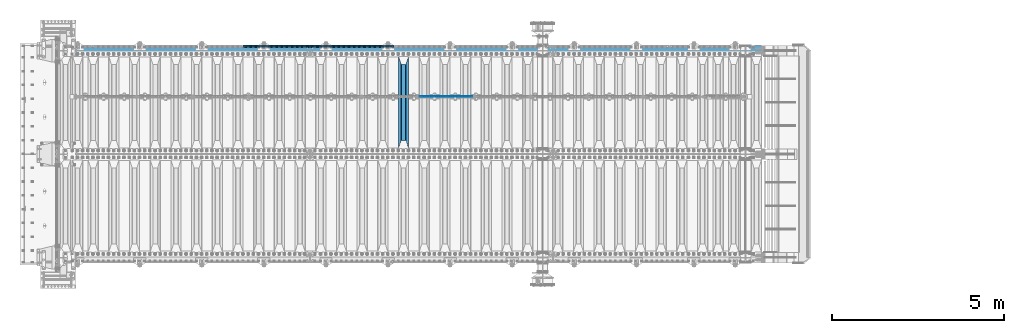
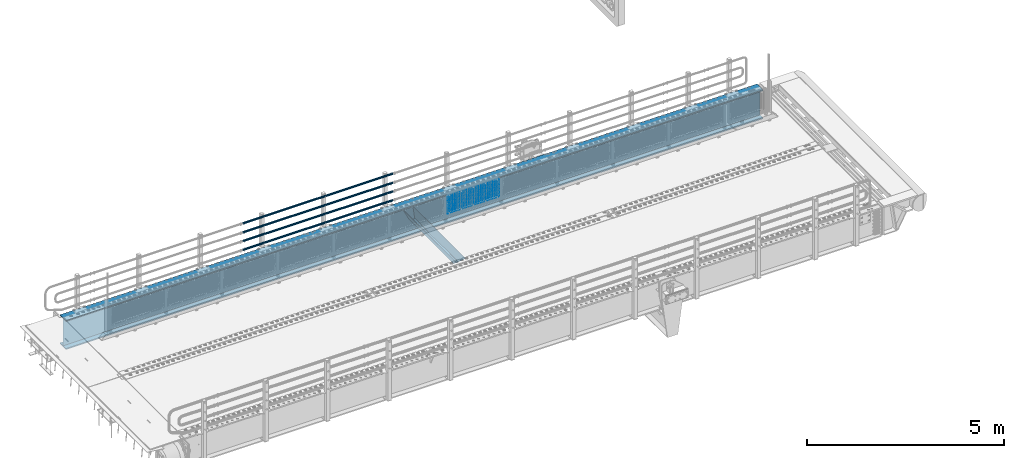
# One storey, part 124 of 242: 23 beams.
"""IFC2X3 building model written with IfcOpenShell, lengths in millimetres."""

import ifcopenshell
import ifcopenshell.guid

model = None  # the IFC model being written
_history = None  # IfcOwnerHistory: only IFC2X3 demands one
_inside = {}  # id of a spatial element -> (the spatial element, [elements in it])
_under = {}  # id of a project, library or spatial element -> (it, [spatial elements below it])
_declared = {}  # id of a project -> (the project, [libraries it declares])
_typed = {}  # id of a type object -> (the type object, [elements of that type])
_made_of = {}  # id of a material, layer set ... -> (it, [elements and type objects made of it])


def new_model(schema):
    """Start an empty IFC model of exactly this schema.

    Asked for "IFC4X3", IfcOpenShell would pick the latest addendum, in which some entities
    have other attributes; the version numbers below select the first issue.
    IFC2X3 requires an IfcOwnerHistory on every rooted entity: one is made here for all.
    """
    global model, _history
    if schema == "IFC4X3":
        model = ifcopenshell.file(schema_version=(4, 3, 0, 0))
    else:
        model = ifcopenshell.file(schema=schema)
    _inside.clear()
    _under.clear()
    _declared.clear()
    _typed.clear()
    _made_of.clear()
    _history = None
    if model.schema == "IFC2X3":
        org = make("IfcOrganization", Name="unknown")
        user = make(
            "IfcPersonAndOrganization",
            ThePerson=make("IfcPerson", FamilyName="unknown"),
            TheOrganization=org,
        )
        app = make(
            "IfcApplication",
            ApplicationDeveloper=org,
            Version="unknown",
            ApplicationFullName="unknown",
            ApplicationIdentifier="unknown",
        )
        _history = make(
            "IfcOwnerHistory",
            OwningUser=user,
            OwningApplication=app,
            ChangeAction="ADDED",
            CreationDate=0,
        )
    return model


def make(cls, **values):
    """One entity of the class cls with the attributes given. An attribute that is None is left unset."""
    return model.create_entity(
        cls, **{name: value for name, value in values.items() if value is not None}
    )


def rooted(cls, **values):
    """An entity with a GlobalId (a new one), such as an element, a storey or a relation."""
    return make(cls, GlobalId=ifcopenshell.guid.new(), OwnerHistory=_history, **values)


def si_unit(unit_type, name, prefix=None):
    """IfcSIUnit, for example si_unit("LENGTHUNIT", "METRE", prefix="MILLI")."""
    return make("IfcSIUnit", UnitType=unit_type, Prefix=prefix, Name=name)


def assignment(units):
    """IfcUnitAssignment: the units of a project."""
    return None if units is None else make("IfcUnitAssignment", Units=units)


def point(xyz):
    """IfcCartesianPoint."""
    return None if xyz is None else make("IfcCartesianPoint", Coordinates=xyz)


def direction(xyz):
    """IfcDirection."""
    return None if xyz is None else make("IfcDirection", DirectionRatios=xyz)


def frame(location, z_axis=None, x_axis=None):
    """IfcAxis2Placement3D, a coordinate frame: its origin and axes. An axis left out is left unset."""
    return make(
        "IfcAxis2Placement3D",
        Location=point(location),
        Axis=direction(z_axis),
        RefDirection=direction(x_axis),
    )


def origin_with_axes():
    """The frame at (0, 0, 0) with the z axis (0, 0, 1) and the x axis (1, 0, 0) written out."""
    return frame((0.0, 0.0, 0.0), z_axis=(0.0, 0.0, 1.0), x_axis=(1.0, 0.0, 0.0))


def place(relative_to, where):
    """IfcLocalPlacement: puts the frame where relative to a parent placement (None: the world)."""
    return make(
        "IfcLocalPlacement", PlacementRelTo=relative_to, RelativePlacement=where
    )


def context(
    kind, dimensions, precision=None, world=None, true_north=None, identifier=None
):
    """IfcGeometricRepresentationContext, for example the 3D "Model" context."""
    return make(
        "IfcGeometricRepresentationContext",
        ContextIdentifier=identifier,
        ContextType=kind,
        CoordinateSpaceDimension=dimensions,
        Precision=precision,
        WorldCoordinateSystem=world,
        TrueNorth=true_north,
    )


def subcontext(parent, identifier, kind, view, scale=None):
    """IfcGeometricRepresentationSubContext, for example "Body" below "Model"."""
    return make(
        "IfcGeometricRepresentationSubContext",
        ContextIdentifier=identifier,
        ContextType=kind,
        ParentContext=parent,
        TargetScale=scale,
        TargetView=view,
    )


def project(units=None, contexts=None):
    """IfcProject with its units and contexts."""
    return rooted(
        "IfcProject",
        Name="project",
        RepresentationContexts=contexts,
        UnitsInContext=assignment(units),
    )


def spatial(cls, under=None, at=None, **own):
    """A site, building, storey or space (cls), placed at a placement, below another one or the project."""
    s = rooted(cls, ObjectPlacement=at, **own)
    if under is not None:
        _under.setdefault(under.id(), (under, []))[1].append(s)
    return s


def faces_of(points, faces, orient=None, outer=None):
    """IfcFace entities. A face is a list of loops; a loop is a list of indices into points, from 0.

    orient and outer hold one flag for each loop. By default every Orientation is true, the
    first loop of a face is its IfcFaceOuterBound and the others are IfcFaceBound.
    """
    made = []
    for i, loops in enumerate(faces):
        bounds = []
        for j, loop in enumerate(loops):
            is_outer = j == 0 if outer is None else outer[i][j]
            bounds.append(
                make(
                    "IfcFaceOuterBound" if is_outer else "IfcFaceBound",
                    Bound=make("IfcPolyLoop", Polygon=[points[k] for k in loop]),
                    Orientation=True if orient is None else orient[i][j],
                )
            )
        made.append(make("IfcFace", Bounds=bounds))
    return made


def faceted_brep(points, faces, orient=None, outer=None, voids=None):
    """IfcFacetedBrep: a solid bounded by flat faces; with voids (closed shells), ...WithVoids."""
    shared = [point(p) for p in points]
    hull = make("IfcClosedShell", CfsFaces=faces_of(shared, faces, orient, outer))
    if voids is None:
        return make("IfcFacetedBrep", Outer=hull)
    return make(
        "IfcFacetedBrepWithVoids",
        Outer=hull,
        Voids=[
            make(cls, CfsFaces=faces_of(shared, fs, o, b)) for cls, fs, o, b in voids
        ],
    )


def shape(context_of_items, identifier, shape_type, items):
    """IfcShapeRepresentation: the items that make up one representation, for example the "Body"."""
    return make(
        "IfcShapeRepresentation",
        ContextOfItems=context_of_items,
        RepresentationIdentifier=identifier,
        RepresentationType=shape_type,
        Items=items,
    )


def material(Name=None, Category=None):
    """IfcMaterial."""
    return make("IfcMaterial", Name=Name, Category=Category)


def made_of(thing, what):
    """Note that an element or type object is made of a material, layer set ...; save() writes the relation."""
    if what is not None:
        _made_of.setdefault(what.id(), (what, []))[1].append(thing)
    return thing


def type_object(cls, material=None, **own):
    """A type object (cls), such as IfcWallType, which elements share."""
    return made_of(rooted(cls, **own), material)


def element(
    cls,
    number,
    at=None,
    inside=None,
    cuts=None,
    type_object=None,
    material=None,
    context=None,
    identifier="Body",
    shape_type=None,
    held_by="IfcProductDefinitionShape",
    body=None,
    shapes=None,
    **own,
):
    """One element of the class cls, such as IfcWall. Its Tag is "e" and its number.

    at: its placement. inside: the storey or other place that contains it. cuts: it is an
    opening in that element (IfcRelVoidsElement). A single representation is given by context,
    identifier, shape_type and body (its items); several are given by shapes. held_by: the class
    of the entity that holds the representations. save() writes the other relations.
    """
    e = rooted(cls, Tag="e%d" % number, ObjectPlacement=at, **own)
    if body is not None:
        shapes = [shape(context, identifier, shape_type, body)]
    if shapes is not None:
        e.Representation = make(held_by, Representations=shapes)
    if inside is not None:
        _inside.setdefault(inside.id(), (inside, []))[1].append(e)
    if cuts is not None:
        rooted(
            "IfcRelVoidsElement", RelatingBuildingElement=cuts, RelatedOpeningElement=e
        )
    if type_object is not None:
        _typed.setdefault(type_object.id(), (type_object, []))[1].append(e)
    return made_of(e, material)


def aggregate(whole, parts):
    """IfcRelAggregates: a whole, such as a stair, and the parts it consists of."""
    return rooted("IfcRelAggregates", RelatingObject=whole, RelatedObjects=parts)


def save(model, path):
    """Write the relations noted so far, then the file.

    IfcRelAggregates (storeys below a building ...), IfcRelContainedInSpatialStructure (elements
    in a storey), IfcRelDefinesByType, IfcRelAssociatesMaterial and IfcRelDeclares: one each for
    every whole, place, type object, material and project.
    """
    for whole, parts in _under.values():
        aggregate(whole, parts)
    for where, things in _inside.values():
        rooted(
            "IfcRelContainedInSpatialStructure",
            RelatedElements=things,
            RelatingStructure=where,
        )
    for kind, things in _typed.values():
        rooted("IfcRelDefinesByType", RelatedObjects=things, RelatingType=kind)
    for what, things in _made_of.values():
        rooted("IfcRelAssociatesMaterial", RelatedObjects=things, RelatingMaterial=what)
    for by, libraries in _declared.values():
        rooted("IfcRelDeclares", RelatingContext=by, RelatedDefinitions=libraries)
    model.write(path)


model = new_model("IFC2X3")

# Units and contexts
model_context = context("Model", 3, precision=1e-05, world=origin_with_axes())
body_context = subcontext(model_context, "Body", "Model", "MODEL_VIEW")
ifc_project = project(units=[si_unit("LENGTHUNIT", "METRE", prefix="MILLI"), si_unit("AREAUNIT", "SQUARE_METRE"), si_unit("VOLUMEUNIT", "CUBIC_METRE"), si_unit("MASSUNIT", "GRAM", prefix="KILO"), si_unit("TIMEUNIT", "SECOND"), si_unit("PLANEANGLEUNIT", "RADIAN"), si_unit("SOLIDANGLEUNIT", "STERADIAN"), si_unit("THERMODYNAMICTEMPERATUREUNIT", "DEGREE_CELSIUS"), si_unit("LUMINOUSINTENSITYUNIT", "LUMEN")], contexts=[model_context])

# Site, building, storey
site_placement = place(None, origin_with_axes())
site = spatial("IfcSite", under=ifc_project, at=site_placement, CompositionType="ELEMENT")
building_placement = place(site_placement, origin_with_axes())
building = spatial("IfcBuilding", under=site, at=building_placement, Name="Standard", CompositionType="ELEMENT")
storey_placement = place(building_placement, origin_with_axes())
storey = spatial("IfcBuildingStorey", under=building, at=storey_placement, Name="Undefined", CompositionType="ELEMENT", Elevation=0.0)

# Beams
ifc_material_1 = material(Name="Misc_Undefined")
beam_type_1 = type_object("IfcBeamType", Name="D3", PredefinedType="NOTDEFINED")
for number, where, z_axis, x_axis in (
    (1, (-31976.0, -19329.5, 851.596999999999), (0.0, 0.0, 1.0), (1.0, 0.0, 0.0)),
    (2, (-31976.0, -19329.5, 669.452), (0.0, 0.0, 1.0), (1.0, 0.0, 0.0)),
    (3, (-31976.0, -19329.5, 523.736), (0.0, 0.0, 1.0), (1.0, 0.0, 0.0)),
    (4, (-31976.0, -19329.5, 487.307), (0.0, 0.0, 1.0), (1.0, 0.0, 0.0)),
    (5, (-31976.0, -19329.5, 705.881), (0.0, 0.0, 1.0), (1.0, 0.0, 0.0)),
    (6, (-31976.0, -19329.5, 596.594), (0.0, 0.0, 1.0), (1.0, 0.0, 0.0)),
    (7, (-31976.0, -19329.5, 450.878), (0.0, 0.0, 1.0), (1.0, 0.0, 0.0)),
    (8, (-31976.0, -19329.5, 815.167999999999), (0.0, 0.0, 1.0), (1.0, 0.0, 0.0)),
    (9, (-31976.0, -19329.5, 888.025999999999), (0.0, 0.0, 1.0), (1.0, 0.0, 0.0)),
    (10, (-31976.0, -19329.5, 778.738999999999), (0.0, 0.0, 1.0), (1.0, 0.0, 0.0)),
    (11, (-31976.0, -19329.5, 742.309999999999), (0.0, 0.0, 1.0), (1.0, 0.0, 0.0)),
    (12, (-31976.0, -19329.5, 633.023), (0.0, 0.0, 1.0), (1.0, 0.0, 0.0)),
    (13, (-31976.0, -19329.5, 560.165), (0.0, 0.0, 1.0), (1.0, 0.0, 0.0)),
    (14, (-31976.0, -19329.5, 414.449), (0.0, 0.0, 1.0), (1.0, 0.0, 0.0)),
):
    element("IfcBeam", number, at=place(storey_placement, frame(where, z_axis=z_axis, x_axis=x_axis)), inside=storey, type_object=beam_type_1, material=ifc_material_1, ObjectType="D3", context=body_context, shape_type="Brep", body=[
        faceted_brep([(0.0, -1.50000000000364, 0.0), (-3.63797880709171e-12, -0.750000000003638, -1.29903810567669), (1523.0, -0.75, -1.29903810567669), (1523.0, -1.5, 0.0), (0.0, 0.749999999996362, -1.29903810567669), (1523.0, 0.75, -1.29903810567669), (-3.63797880709171e-12, 1.49999999999636, 0.0), (1523.0, 1.5, 0.0), (0.0, 0.749999999996362, 1.29903810567669), (1523.0, 0.75, 1.29903810567669), (-3.63797880709171e-12, -0.750000000003638, 1.29903810567669), (1523.0, -0.75, 1.29903810567669)], [[[0, 1, 2, 3]], [[1, 4, 5, 2]], [[4, 6, 7, 5]], [[6, 8, 9, 7]], [[8, 10, 11, 9]], [[10, 0, 3, 11]], [[5, 7, 9, 11, 3, 2]], [[10, 8, 6, 4, 1, 0]]]),
    ])
beam_1_placement = place(storey_placement, frame((-31951.0, -19329.5, 353.02), z_axis=(0.0, 0.0, 1.0), x_axis=(1.0, 0.0, 0.0)))
element("IfcBeam", 15, at=beam_1_placement, inside=storey, type_object=beam_type_1, material=ifc_material_1, ObjectType="D3", context=body_context, shape_type="Brep", body=[
    faceted_brep([(0.0, -1.50000000000364, 0.0), (-3.63797880709171e-12, -0.750000000003638, -1.29903810567669), (1473.0, -0.75, -1.29903810567669), (1473.0, -1.5, 0.0), (0.0, 0.749999999996362, -1.29903810567669), (1473.0, 0.75, -1.29903810567663), (-3.63797880709171e-12, 1.49999999999636, 0.0), (1473.0, 1.5, 0.0), (0.0, 0.749999999996362, 1.29903810567669), (1473.0, 0.75, 1.29903810567669), (-3.63797880709171e-12, -0.750000000003638, 1.29903810567669), (1473.0, -0.75, 1.29903810567669)], [[[0, 1, 2, 3]], [[1, 4, 5, 2]], [[4, 6, 7, 5]], [[6, 8, 9, 7]], [[8, 10, 11, 9]], [[10, 0, 3, 11]], [[5, 7, 9, 11, 3, 2]], [[10, 8, 6, 4, 1, 0]]]),
])
beam_2_placement = place(storey_placement, frame((-31976.0, -19329.5, 378.02), z_axis=(0.0, 0.0, 1.0), x_axis=(1.0, 0.0, 0.0)))
element("IfcBeam", 16, at=beam_2_placement, inside=storey, type_object=beam_type_1, material=ifc_material_1, ObjectType="D3", context=body_context, shape_type="Brep", body=[
    faceted_brep([(0.0, -1.50000000000364, 0.0), (-3.63797880709171e-12, -0.750000000003638, -1.29903810567669), (1523.0, -0.75, -1.29903810567669), (1523.0, -1.5, 0.0), (0.0, 0.749999999996362, -1.29903810567669), (1523.0, 0.75, -1.29903810567669), (-3.63797880709171e-12, 1.49999999999636, 0.0), (1523.0, 1.5, 0.0), (0.0, 0.749999999996362, 1.29903810567669), (1523.0, 0.75, 1.29903810567669), (-3.63797880709171e-12, -0.750000000003638, 1.29903810567669), (1523.0, -0.75, 1.29903810567669)], [[[0, 1, 2, 3]], [[1, 4, 5, 2]], [[4, 6, 7, 5]], [[6, 8, 9, 7]], [[8, 10, 11, 9]], [[10, 0, 3, 11]], [[5, 7, 9, 11, 3, 2]], [[10, 8, 6, 4, 1, 0]]]),
])
beam_3_placement = place(storey_placement, frame((-31951.0, -19329.5, 913.02), z_axis=(0.0, 0.0, 1.0), x_axis=(1.0, 0.0, 0.0)))
element("IfcBeam", 17, at=beam_3_placement, inside=storey, type_object=beam_type_1, material=ifc_material_1, ObjectType="D3", context=body_context, shape_type="Brep", body=[
    faceted_brep([(0.0, -1.50000000000364, 0.0), (-3.63797880709171e-12, -0.750000000003638, -1.29903810567669), (1473.0, -0.75, -1.29903810567669), (1473.0, -1.5, 0.0), (0.0, 0.749999999996362, -1.29903810567669), (1473.0, 0.75, -1.29903810567663), (-3.63797880709171e-12, 1.49999999999636, 0.0), (1473.0, 1.5, 0.0), (0.0, 0.749999999996362, 1.29903810567669), (1473.0, 0.75, 1.29903810567669), (-3.63797880709171e-12, -0.750000000003638, 1.29903810567669), (1473.0, -0.75, 1.29903810567669)], [[[0, 1, 2, 3]], [[1, 4, 5, 2]], [[4, 6, 7, 5]], [[6, 8, 9, 7]], [[8, 10, 11, 9]], [[10, 0, 3, 11]], [[5, 7, 9, 11, 3, 2]], [[10, 8, 6, 4, 1, 0]]]),
])
ifc_material_2 = material()
beam_type_2 = type_object("IfcBeamType", PredefinedType="NOTDEFINED")
beam_4_placement = place(storey_placement, frame((-32722.0000000001, -17870.1499999999, 149.849999999726), z_axis=(0.0, 0.0, -1.0), x_axis=(-1.0, 0.0, 0.0)))
element("IfcBeam", 18, at=beam_4_placement, inside=storey, type_object=beam_type_2, material=ifc_material_2, context=body_context, shape_type="Brep", body=[
    faceted_brep([(0.0, -26.5499999999993, 0.0), (0.0, -24.5290015881765, 10.1602451292931), (4384.00249699992, -24.5290015881765, 10.1602451292931), (4384.00249699992, -26.5499999999993, 0.0), (0.0, -18.7736850405017, 18.7736850405028), (4384.00249699992, -18.7736850405017, 18.7736850405028), (0.0, -10.1602451292929, 24.5290015881747), (4384.00249699992, -10.1602451292929, 24.5290015881747), (0.0, 0.0, 26.55), (4384.00249699992, 0.0, 26.55), (0.0, 10.1602451292929, 24.5290015881747), (4384.00249699992, 10.1602451292929, 24.5290015881747), (0.0, 18.7736850405017, 18.7736850405028), (4384.00249699992, 18.7736850405017, 18.7736850405028), (0.0, 24.5290015881765, 10.1602451292931), (4384.00249699992, 24.5290015881765, 10.1602451292931), (0.0, 26.5499999999993, 0.0), (4384.00249699992, 26.5499999999993, 0.0), (0.0, 24.5290015881765, -10.1602451292931), (4384.00249699992, 24.5290015881765, -10.1602451292931), (0.0, 18.7736850405017, -18.7736850405028), (4384.00249699992, 18.7736850405017, -18.7736850405028), (0.0, 10.1602451292929, -24.5290015881747), (4384.00249699992, 10.1602451292929, -24.5290015881747), (0.0, 0.0, -26.55), (4384.00249699992, 0.0, -26.55), (0.0, -10.1602451292929, -24.5290015881747), (4384.00249699992, -10.1602451292929, -24.5290015881747), (0.0, -18.7736850405017, -18.7736850405028), (4384.00249699992, -18.7736850405017, -18.7736850405028), (0.0, -24.5290015881765, -10.1602451292931), (4384.00249699992, -24.5290015881765, -10.1602451292931), (0.0, -30.1500000000015, 0.0), (0.0, -27.8549679052157, -11.5379054858058), (4384.00249699992, -27.8549679052157, -11.5379054858075), (4384.00249699992, -30.1500000000015, 0.0), (0.0, -21.3192694527752, -21.3192694527752), (4384.00249699992, -21.3192694527752, -21.3192694527744), (0.0, -11.5379054858058, -27.8549679052157), (4384.00249699992, -11.5379054858058, -27.8549679052153), (0.0, 0.0, -30.1500000000015), (4384.00249699992, 0.0, -30.15), (0.0, 11.5379054858058, -27.8549679052157), (4384.00249699992, 11.5379054858058, -27.8549679052153), (0.0, 21.3192694527752, -21.3192694527752), (4384.00249699992, 21.3192694527752, -21.3192694527744), (0.0, 27.8549679052157, -11.5379054858058), (4384.00249699992, 27.8549679052157, -11.5379054858074), (0.0, 30.1500000000015, 0.0), (4384.00249699992, 30.1500000000015, 0.0), (0.0, 27.8549679052157, 11.5379054858058), (4384.00249699992, 27.8549679052157, 11.5379054858075), (0.0, 21.3192694527752, 21.3192694527752), (4384.00249699992, 21.3192694527752, 21.3192694527744), (0.0, 11.5379054858058, 27.8549679052157), (4384.00249699992, 11.5379054858058, 27.8549679052153), (0.0, 0.0, 30.1500000000015), (4384.00249699992, 0.0, 30.15), (0.0, -11.5379054858058, 27.8549679052157), (4384.00249699992, -11.5379054858058, 27.8549679052153), (0.0, -21.3192694527752, 21.3192694527752), (4384.00249699992, -21.3192694527752, 21.3192694527744), (0.0, -27.8549679052157, 11.5379054858058), (4384.00249699992, -27.8549679052157, 11.5379054858075)], [[[0, 1, 2, 3]], [[1, 4, 5, 2]], [[4, 6, 7, 5]], [[6, 8, 9, 7]], [[8, 10, 11, 9]], [[10, 12, 13, 11]], [[12, 14, 15, 13]], [[14, 16, 17, 15]], [[16, 18, 19, 17]], [[18, 20, 21, 19]], [[20, 22, 23, 21]], [[22, 24, 25, 23]], [[24, 26, 27, 25]], [[26, 28, 29, 27]], [[28, 30, 31, 29]], [[30, 0, 3, 31]], [[32, 33, 34, 35]], [[33, 36, 37, 34]], [[36, 38, 39, 37]], [[38, 40, 41, 39]], [[40, 42, 43, 41]], [[42, 44, 45, 43]], [[44, 46, 47, 45]], [[46, 48, 49, 47]], [[48, 50, 51, 49]], [[50, 52, 53, 51]], [[52, 54, 55, 53]], [[54, 56, 57, 55]], [[56, 58, 59, 57]], [[58, 60, 61, 59]], [[60, 62, 63, 61]], [[62, 32, 35, 63]], [[37, 39, 41, 43, 45, 47, 49, 51, 53, 55, 57, 59, 61, 63, 35, 34], [5, 7, 9, 11, 13, 15, 17, 19, 21, 23, 25, 27, 29, 31, 3, 2]], [[62, 60, 58, 56, 54, 52, 50, 48, 46, 44, 42, 40, 38, 36, 33, 32], [30, 28, 26, 24, 22, 20, 18, 16, 14, 12, 10, 8, 6, 4, 1, 0]]]),
])
beam_5_placement = place(storey_placement, frame((-32722.0000000001, -17870.1499999999, 420.149999999729), z_axis=(0.0, 0.0, -1.0), x_axis=(-1.0, 0.0, 0.0)))
element("IfcBeam", 19, at=beam_5_placement, inside=storey, type_object=beam_type_2, material=ifc_material_2, context=body_context, shape_type="Brep", body=[
    faceted_brep([(0.0, -26.5499999999993, 0.0), (0.0, -24.5290015881765, 10.1602451292931), (4384.00249699992, -24.5290015881765, 10.1602451292931), (4384.00249699992, -26.5499999999993, 0.0), (0.0, -18.7736850405017, 18.7736850405028), (4384.00249699992, -18.7736850405017, 18.7736850405028), (0.0, -10.1602451292929, 24.5290015881747), (4384.00249699992, -10.1602451292929, 24.5290015881747), (0.0, 0.0, 26.55), (4384.00249699992, 0.0, 26.55), (0.0, 10.1602451292929, 24.5290015881747), (4384.00249699992, 10.1602451292929, 24.5290015881747), (0.0, 18.7736850405017, 18.7736850405028), (4384.00249699992, 18.7736850405017, 18.7736850405028), (0.0, 24.5290015881765, 10.1602451292931), (4384.00249699992, 24.5290015881765, 10.1602451292931), (0.0, 26.5499999999993, 0.0), (4384.00249699992, 26.5499999999993, 0.0), (0.0, 24.5290015881765, -10.1602451292931), (4384.00249699992, 24.5290015881765, -10.1602451292931), (0.0, 18.7736850405017, -18.7736850405028), (4384.00249699992, 18.7736850405017, -18.7736850405028), (0.0, 10.1602451292929, -24.5290015881747), (4384.00249699992, 10.1602451292929, -24.5290015881747), (0.0, 0.0, -26.55), (4384.00249699992, 0.0, -26.55), (0.0, -10.1602451292929, -24.5290015881747), (4384.00249699992, -10.1602451292929, -24.5290015881747), (0.0, -18.7736850405017, -18.7736850405028), (4384.00249699992, -18.7736850405017, -18.7736850405028), (0.0, -24.5290015881765, -10.1602451292931), (4384.00249699992, -24.5290015881765, -10.1602451292931), (0.0, -30.1500000000015, 0.0), (0.0, -27.8549679052157, -11.5379054858058), (4384.00249699992, -27.8549679052157, -11.5379054858075), (4384.00249699992, -30.1500000000015, 0.0), (0.0, -21.3192694527752, -21.3192694527752), (4384.00249699992, -21.3192694527752, -21.3192694527744), (0.0, -11.5379054858058, -27.8549679052157), (4384.00249699992, -11.5379054858058, -27.8549679052153), (0.0, 0.0, -30.1500000000015), (4384.00249699992, 0.0, -30.15), (0.0, 11.5379054858058, -27.8549679052157), (4384.00249699992, 11.5379054858058, -27.8549679052153), (0.0, 21.3192694527752, -21.3192694527752), (4384.00249699992, 21.3192694527752, -21.3192694527744), (0.0, 27.8549679052157, -11.5379054858058), (4384.00249699992, 27.8549679052157, -11.5379054858074), (0.0, 30.1500000000015, 0.0), (4384.00249699992, 30.1500000000015, 0.0), (0.0, 27.8549679052157, 11.5379054858058), (4384.00249699992, 27.8549679052157, 11.5379054858075), (0.0, 21.3192694527752, 21.3192694527752), (4384.00249699992, 21.3192694527752, 21.3192694527744), (0.0, 11.5379054858058, 27.8549679052157), (4384.00249699992, 11.5379054858058, 27.8549679052153), (0.0, 0.0, 30.1500000000015), (4384.00249699992, 0.0, 30.15), (0.0, -11.5379054858058, 27.8549679052157), (4384.00249699992, -11.5379054858058, 27.8549679052153), (0.0, -21.3192694527752, 21.3192694527752), (4384.00249699992, -21.3192694527752, 21.3192694527744), (0.0, -27.8549679052157, 11.5379054858058), (4384.00249699992, -27.8549679052157, 11.5379054858075)], [[[0, 1, 2, 3]], [[1, 4, 5, 2]], [[4, 6, 7, 5]], [[6, 8, 9, 7]], [[8, 10, 11, 9]], [[10, 12, 13, 11]], [[12, 14, 15, 13]], [[14, 16, 17, 15]], [[16, 18, 19, 17]], [[18, 20, 21, 19]], [[20, 22, 23, 21]], [[22, 24, 25, 23]], [[24, 26, 27, 25]], [[26, 28, 29, 27]], [[28, 30, 31, 29]], [[30, 0, 3, 31]], [[32, 33, 34, 35]], [[33, 36, 37, 34]], [[36, 38, 39, 37]], [[38, 40, 41, 39]], [[40, 42, 43, 41]], [[42, 44, 45, 43]], [[44, 46, 47, 45]], [[46, 48, 49, 47]], [[48, 50, 51, 49]], [[50, 52, 53, 51]], [[52, 54, 55, 53]], [[54, 56, 57, 55]], [[56, 58, 59, 57]], [[58, 60, 61, 59]], [[60, 62, 63, 61]], [[62, 32, 35, 63]], [[37, 39, 41, 43, 45, 47, 49, 51, 53, 55, 57, 59, 61, 63, 35, 34], [5, 7, 9, 11, 13, 15, 17, 19, 21, 23, 25, 27, 29, 31, 3, 2]], [[62, 60, 58, 56, 54, 52, 50, 48, 46, 44, 42, 40, 38, 36, 33, 32], [30, 28, 26, 24, 22, 20, 18, 16, 14, 12, 10, 8, 6, 4, 1, 0]]]),
])
beam_6_placement = place(storey_placement, frame((-32722.0000000001, -17870.1499999999, 969.849999999726), z_axis=(0.0, 0.0, -1.0), x_axis=(-1.0, 0.0, 0.0)))
element("IfcBeam", 20, at=beam_6_placement, inside=storey, type_object=beam_type_2, material=ifc_material_2, context=body_context, shape_type="Brep", body=[
    faceted_brep([(0.0, -26.5499999999993, 0.0), (0.0, -24.5290015881765, 10.1602451292931), (4384.00249699992, -24.5290015881765, 10.1602451292931), (4384.00249699992, -26.5499999999993, 0.0), (0.0, -18.7736850405017, 18.7736850405028), (4384.00249699992, -18.7736850405017, 18.7736850405028), (0.0, -10.1602451292929, 24.5290015881747), (4384.00249699992, -10.1602451292929, 24.5290015881747), (0.0, 0.0, 26.55), (4384.00249699992, 0.0, 26.55), (0.0, 10.1602451292929, 24.5290015881747), (4384.00249699992, 10.1602451292929, 24.5290015881747), (0.0, 18.7736850405017, 18.7736850405028), (4384.00249699992, 18.7736850405017, 18.7736850405028), (0.0, 24.5290015881765, 10.1602451292931), (4384.00249699992, 24.5290015881765, 10.1602451292931), (0.0, 26.5499999999993, 0.0), (4384.00249699992, 26.5499999999993, 0.0), (0.0, 24.5290015881765, -10.1602451292931), (4384.00249699992, 24.5290015881765, -10.1602451292931), (0.0, 18.7736850405017, -18.7736850405028), (4384.00249699992, 18.7736850405017, -18.7736850405028), (0.0, 10.1602451292929, -24.5290015881747), (4384.00249699992, 10.1602451292929, -24.5290015881747), (0.0, 0.0, -26.55), (4384.00249699992, 0.0, -26.55), (0.0, -10.1602451292929, -24.5290015881747), (4384.00249699992, -10.1602451292929, -24.5290015881747), (0.0, -18.7736850405017, -18.7736850405028), (4384.00249699992, -18.7736850405017, -18.7736850405028), (0.0, -24.5290015881765, -10.1602451292931), (4384.00249699992, -24.5290015881765, -10.1602451292931), (0.0, -30.1500000000015, 0.0), (0.0, -27.8549679052157, -11.5379054858058), (4384.00249699992, -27.8549679052157, -11.5379054858075), (4384.00249699992, -30.1500000000015, 0.0), (0.0, -21.3192694527752, -21.3192694527752), (4384.00249699992, -21.3192694527752, -21.3192694527744), (0.0, -11.5379054858058, -27.8549679052157), (4384.00249699992, -11.5379054858058, -27.8549679052153), (0.0, 0.0, -30.1500000000015), (4384.00249699992, 0.0, -30.15), (0.0, 11.5379054858058, -27.8549679052157), (4384.00249699992, 11.5379054858058, -27.8549679052153), (0.0, 21.3192694527752, -21.3192694527752), (4384.00249699992, 21.3192694527752, -21.3192694527744), (0.0, 27.8549679052157, -11.5379054858058), (4384.00249699992, 27.8549679052157, -11.5379054858074), (0.0, 30.1500000000015, 0.0), (4384.00249699992, 30.1500000000015, 0.0), (0.0, 27.8549679052157, 11.5379054858058), (4384.00249699992, 27.8549679052157, 11.5379054858075), (0.0, 21.3192694527752, 21.3192694527752), (4384.00249699992, 21.3192694527752, 21.3192694527744), (0.0, 11.5379054858058, 27.8549679052157), (4384.00249699992, 11.5379054858058, 27.8549679052153), (0.0, 0.0, 30.1500000000015), (4384.00249699992, 0.0, 30.15), (0.0, -11.5379054858058, 27.8549679052157), (4384.00249699992, -11.5379054858058, 27.8549679052153), (0.0, -21.3192694527752, 21.3192694527752), (4384.00249699992, -21.3192694527752, 21.3192694527744), (0.0, -27.8549679052157, 11.5379054858058), (4384.00249699992, -27.8549679052157, 11.5379054858075)], [[[0, 1, 2, 3]], [[1, 4, 5, 2]], [[4, 6, 7, 5]], [[6, 8, 9, 7]], [[8, 10, 11, 9]], [[10, 12, 13, 11]], [[12, 14, 15, 13]], [[14, 16, 17, 15]], [[16, 18, 19, 17]], [[18, 20, 21, 19]], [[20, 22, 23, 21]], [[22, 24, 25, 23]], [[24, 26, 27, 25]], [[26, 28, 29, 27]], [[28, 30, 31, 29]], [[30, 0, 3, 31]], [[32, 33, 34, 35]], [[33, 36, 37, 34]], [[36, 38, 39, 37]], [[38, 40, 41, 39]], [[40, 42, 43, 41]], [[42, 44, 45, 43]], [[44, 46, 47, 45]], [[46, 48, 49, 47]], [[48, 50, 51, 49]], [[50, 52, 53, 51]], [[52, 54, 55, 53]], [[54, 56, 57, 55]], [[56, 58, 59, 57]], [[58, 60, 61, 59]], [[60, 62, 63, 61]], [[62, 32, 35, 63]], [[37, 39, 41, 43, 45, 47, 49, 51, 53, 55, 57, 59, 61, 63, 35, 34], [5, 7, 9, 11, 13, 15, 17, 19, 21, 23, 25, 27, 29, 31, 3, 2]], [[62, 60, 58, 56, 54, 52, 50, 48, 46, 44, 42, 40, 38, 36, 33, 32], [30, 28, 26, 24, 22, 20, 18, 16, 14, 12, 10, 8, 6, 4, 1, 0]]]),
])
beam_7_placement = place(storey_placement, frame((-32722.0000000001, -17870.1499999999, 689.849999999726), z_axis=(0.0, 0.0, -1.0), x_axis=(-1.0, 0.0, 0.0)))
element("IfcBeam", 21, at=beam_7_placement, inside=storey, type_object=beam_type_2, material=ifc_material_2, context=body_context, shape_type="Brep", body=[
    faceted_brep([(0.0, -26.5499999999993, 0.0), (0.0, -24.5290015881765, 10.1602451292931), (4384.00249699992, -24.5290015881765, 10.1602451292931), (4384.00249699992, -26.5499999999993, 0.0), (0.0, -18.7736850405017, 18.7736850405028), (4384.00249699992, -18.7736850405017, 18.7736850405028), (0.0, -10.1602451292929, 24.5290015881747), (4384.00249699992, -10.1602451292929, 24.5290015881747), (0.0, 0.0, 26.55), (4384.00249699992, 0.0, 26.55), (0.0, 10.1602451292929, 24.5290015881747), (4384.00249699992, 10.1602451292929, 24.5290015881747), (0.0, 18.7736850405017, 18.7736850405028), (4384.00249699992, 18.7736850405017, 18.7736850405028), (0.0, 24.5290015881765, 10.1602451292931), (4384.00249699992, 24.5290015881765, 10.1602451292931), (0.0, 26.5499999999993, 0.0), (4384.00249699992, 26.5499999999993, 0.0), (0.0, 24.5290015881765, -10.1602451292931), (4384.00249699992, 24.5290015881765, -10.1602451292931), (0.0, 18.7736850405017, -18.7736850405028), (4384.00249699992, 18.7736850405017, -18.7736850405028), (0.0, 10.1602451292929, -24.5290015881747), (4384.00249699992, 10.1602451292929, -24.5290015881747), (0.0, 0.0, -26.55), (4384.00249699992, 0.0, -26.55), (0.0, -10.1602451292929, -24.5290015881747), (4384.00249699992, -10.1602451292929, -24.5290015881747), (0.0, -18.7736850405017, -18.7736850405028), (4384.00249699992, -18.7736850405017, -18.7736850405028), (0.0, -24.5290015881765, -10.1602451292931), (4384.00249699992, -24.5290015881765, -10.1602451292931), (0.0, -30.1500000000015, 0.0), (0.0, -27.8549679052157, -11.5379054858058), (4384.00249699992, -27.8549679052157, -11.5379054858075), (4384.00249699992, -30.1500000000015, 0.0), (0.0, -21.3192694527752, -21.3192694527752), (4384.00249699992, -21.3192694527752, -21.3192694527744), (0.0, -11.5379054858058, -27.8549679052157), (4384.00249699992, -11.5379054858058, -27.8549679052153), (0.0, 0.0, -30.1500000000015), (4384.00249699992, 0.0, -30.15), (0.0, 11.5379054858058, -27.8549679052157), (4384.00249699992, 11.5379054858058, -27.8549679052153), (0.0, 21.3192694527752, -21.3192694527752), (4384.00249699992, 21.3192694527752, -21.3192694527744), (0.0, 27.8549679052157, -11.5379054858058), (4384.00249699992, 27.8549679052157, -11.5379054858074), (0.0, 30.1500000000015, 0.0), (4384.00249699992, 30.1500000000015, 0.0), (0.0, 27.8549679052157, 11.5379054858058), (4384.00249699992, 27.8549679052157, 11.5379054858075), (0.0, 21.3192694527752, 21.3192694527752), (4384.00249699992, 21.3192694527752, 21.3192694527744), (0.0, 11.5379054858058, 27.8549679052157), (4384.00249699992, 11.5379054858058, 27.8549679052153), (0.0, 0.0, 30.1500000000015), (4384.00249699992, 0.0, 30.15), (0.0, -11.5379054858058, 27.8549679052157), (4384.00249699992, -11.5379054858058, 27.8549679052153), (0.0, -21.3192694527752, 21.3192694527752), (4384.00249699992, -21.3192694527752, 21.3192694527744), (0.0, -27.8549679052157, 11.5379054858058), (4384.00249699992, -27.8549679052157, 11.5379054858075)], [[[0, 1, 2, 3]], [[1, 4, 5, 2]], [[4, 6, 7, 5]], [[6, 8, 9, 7]], [[8, 10, 11, 9]], [[10, 12, 13, 11]], [[12, 14, 15, 13]], [[14, 16, 17, 15]], [[16, 18, 19, 17]], [[18, 20, 21, 19]], [[20, 22, 23, 21]], [[22, 24, 25, 23]], [[24, 26, 27, 25]], [[26, 28, 29, 27]], [[28, 30, 31, 29]], [[30, 0, 3, 31]], [[32, 33, 34, 35]], [[33, 36, 37, 34]], [[36, 38, 39, 37]], [[38, 40, 41, 39]], [[40, 42, 43, 41]], [[42, 44, 45, 43]], [[44, 46, 47, 45]], [[46, 48, 49, 47]], [[48, 50, 51, 49]], [[50, 52, 53, 51]], [[52, 54, 55, 53]], [[54, 56, 57, 55]], [[56, 58, 59, 57]], [[58, 60, 61, 59]], [[60, 62, 63, 61]], [[62, 32, 35, 63]], [[37, 39, 41, 43, 45, 47, 49, 51, 53, 55, 57, 59, 61, 63, 35, 34], [5, 7, 9, 11, 13, 15, 17, 19, 21, 23, 25, 27, 29, 31, 3, 2]], [[62, 60, 58, 56, 54, 52, 50, 48, 46, 44, 42, 40, 38, 36, 33, 32], [30, 28, 26, 24, 22, 20, 18, 16, 14, 12, 10, 8, 6, 4, 1, 0]]]),
])
ifc_material_3 = material(Name="STEEL/S355N")
beam_type_3 = type_object("IfcBeamType", PredefinedType="NOTDEFINED")
beam_8_placement = place(storey_placement, frame((-32450.0, -20825.0, -115.0), z_axis=(0.0, 0.0, 1.0), x_axis=(0.0, 1.0, 0.0)))
element("IfcBeam", 22, at=beam_8_placement, inside=storey, type_object=beam_type_3, material=ifc_material_3, context=body_context, shape_type="Brep", body=[
    faceted_brep([(0.0, 150.0, 115.0), (0.0, 143.689999999999, 115.0), (2650.00000000297, 143.689999999999, 115.0), (2650.00000000297, 150.0, 115.0), (2650.00000000297, 142.059565218402, 110.000000003099), (2650.00000000297, 148.369565218403, 110.000000003099), (2441.90079219209, -80.1103600731112, -98.0992078077845), (2437.7588105432, -77.5672621345584, -102.241189456673), (2434.06523489747, -74.4080125315522, -105.934765102404), (2430.91086095089, -70.710272125576, -109.089139048974), (2428.37322971128, -66.5649389910068, -111.626770288588), (2426.51472138055, -62.0739139532889, -113.485278619323), (2425.38102192092, -57.3475956567672, -114.618978078955), (2424.99999999987, -52.5021667386536, -115.0), (2424.99999999987, 52.5021667386536, -115.0), (2425.38102192092, 57.3475956567672, -114.618978078955), (2426.51472138055, 62.0739139532889, -113.485278619323), (2428.37322971128, 66.5649389910068, -111.626770288588), (2430.91086095089, 70.710272125576, -109.089139048974), (2434.06523489747, 74.4080125315522, -105.934765102404), (2437.7588105432, 77.5672621345584, -102.241189456673), (2441.90079219209, 80.1103600731112, -98.0992078077846), (2446.38936140511, 81.9747917625791, -93.6106385947584), (2448.2494850041, 76.2713538057251, -91.7505149957729), (2444.62967112262, 74.76777986261, -95.3703288772456), (2441.28936334126, 72.7168944282894, -98.710636658607), (2438.31067330438, 70.1691124903846, -101.689326695487), (2435.76682334747, 67.1870637758839, -104.233176652398), (2433.72034654133, 63.8440531834895, -106.279653458539), (2432.22154950042, 60.222258798236, -107.778450499454), (2431.30727574265, 56.4107117849089, -108.692724257221), (2430.99999999987, 52.5031078186876, -109.0), (2430.99999999987, -52.5031078186876, -109.0), (2431.30727574265, -56.4107117849089, -108.692724257221), (2432.22154950042, -60.222258798236, -107.778450499454), (2433.72034654133, -63.8440531834895, -106.279653458539), (2435.76682334747, -67.1870637758839, -104.233176652398), (2438.31067330438, -70.1691124903846, -101.689326695487), (2441.28936334126, -72.7168944282894, -98.7106366586071), (2444.62967112262, -74.76777986261, -95.3703288772457), (2448.2494850041, -76.2713538057251, -91.7505149957729), (2650.00000000297, -142.059565218402, 110.000000003099), (2650.00000000297, -148.369565218403, 110.000000003099), (2446.38936140511, -81.9747917625791, -93.6106385947584), (2650.00000000297, -143.689999999999, 115.0), (2650.00000000297, -150.0, 115.0), (0.0, -143.689999999999, 115.0), (0.0, -150.0, 115.0), (0.0, -148.369565218261, 110.000000002669), (203.610638597427, -81.9747917625791, -93.6106385947584), (208.099207810454, -80.1103600731112, -98.0992078077845), (212.241189459342, -77.5672621345584, -102.241189456673), (215.934765105074, -74.4080125315522, -105.934765102404), (219.089139051644, -70.710272125576, -109.089139048974), (221.626770291256, -66.5649389910068, -111.626770288588), (223.485278621993, -62.0739139532889, -113.485278619323), (224.618978081624, -57.3475956567672, -114.618978078955), (225.00000000267, -52.5021667386536, -115.0), (225.00000000267, 52.5021667386536, -115.0), (224.618978081624, 57.3475956567672, -114.618978078955), (223.485278621993, 62.0739139532889, -113.485278619323), (221.626770291256, 66.5649389910068, -111.626770288588), (219.089139051644, 70.710272125576, -109.089139048974), (215.934765105074, 74.4080125315522, -105.934765102404), (212.241189459342, 77.5672621345584, -102.241189456673), (208.099207810454, 80.1103600731112, -98.0992078077846), (203.610638597427, 81.9747917625791, -93.6106385947584), (0.0, 148.369565218261, 110.000000002669), (0.0, 142.05956521826, 110.000000002669), (201.750514998443, 76.2713538057251, -91.7505149957729), (205.370328879915, 74.76777986261, -95.3703288772456), (208.710636661275, 72.7168944282894, -98.710636658607), (211.689326698157, 70.1691124903846, -101.689326695487), (214.233176655067, 67.1870637758839, -104.233176652398), (216.279653461206, 63.8440531834895, -106.279653458539), (217.778450502123, 60.222258798236, -107.778450499454), (218.69272425989, 56.4107117849089, -108.692724257221), (219.00000000267, 52.5031078186876, -109.0), (219.00000000267, -52.5031078186876, -109.0), (218.69272425989, -56.4107117849089, -108.692724257221), (217.778450502123, -60.222258798236, -107.778450499454), (216.279653461206, -63.8440531834895, -106.279653458539), (214.233176655067, -67.1870637758839, -104.233176652398), (211.689326698157, -70.1691124903846, -101.689326695487), (208.710636661275, -72.7168944282894, -98.7106366586071), (205.370328879915, -74.76777986261, -95.3703288772457), (201.750514998443, -76.2713538057251, -91.7505149957729), (0.0, -142.05956521826, 110.000000002669)], [[[0, 1, 2, 3]], [[3, 2, 4, 5]], [[6, 7, 8, 9, 10, 11, 12, 13, 14, 15, 16, 17, 18, 19, 20, 21, 22, 5, 4, 23, 24, 25, 26, 27, 28, 29, 30, 31, 32, 33, 34, 35, 36, 37, 38, 39, 40, 41, 42, 43]], [[44, 45, 42, 41]], [[46, 47, 45, 44]], [[43, 42, 45, 47, 48, 49]], [[6, 43, 49, 50]], [[7, 6, 50, 51]], [[8, 7, 51, 52]], [[9, 8, 52, 53]], [[10, 9, 53, 54]], [[11, 10, 54, 55]], [[12, 11, 55, 56]], [[13, 12, 56, 57]], [[14, 13, 57, 58]], [[15, 14, 58, 59]], [[16, 15, 59, 60]], [[17, 16, 60, 61]], [[18, 17, 61, 62]], [[19, 18, 62, 63]], [[20, 19, 63, 64]], [[21, 20, 64, 65]], [[22, 21, 65, 66]], [[0, 3, 5, 22, 66, 67]], [[1, 0, 67, 68]], [[23, 4, 2, 1, 68, 69]], [[24, 23, 69, 70]], [[25, 24, 70, 71]], [[26, 25, 71, 72]], [[27, 26, 72, 73]], [[28, 27, 73, 74]], [[29, 28, 74, 75]], [[30, 29, 75, 76]], [[31, 30, 76, 77]], [[32, 31, 77, 78]], [[33, 32, 78, 79]], [[34, 33, 79, 80]], [[35, 34, 80, 81]], [[36, 35, 81, 82]], [[37, 36, 82, 83]], [[38, 37, 83, 84]], [[39, 38, 84, 85]], [[40, 39, 85, 86]], [[46, 44, 41, 40, 86, 87]], [[47, 46, 87, 48]], [[86, 85, 84, 83, 82, 81, 80, 79, 78, 77, 76, 75, 74, 73, 72, 71, 70, 69, 68, 67, 66, 65, 64, 63, 62, 61, 60, 59, 58, 57, 56, 55, 54, 53, 52, 51, 50, 49, 48, 87]]]),
])
beam_type_4 = type_object("IfcBeamType", Name="HEB900", PredefinedType="NOTDEFINED")
beam_9_placement = place(storey_placement, frame((-42440.0, -18000.0, -450.0), z_axis=(0.0, 0.0, 1.0), x_axis=(1.0, 0.0, 0.0)))
element("IfcBeam", 23, at=beam_9_placement, inside=storey, type_object=beam_type_4, material=ifc_material_3, ObjectType="HEB900", context=body_context, shape_type="Brep", body=[
    faceted_brep([(0.0, 150.0, -450.0), (0.0, 150.0, -415.0), (20380.0, 150.0, -415.0), (20380.0, 150.0, -450.0), (0.0, 9.25, -415.0), (20380.0, 9.25, -415.0), (0.0, 9.25, 415.0), (20380.0, 9.25, 415.0), (0.0, 150.0, 415.0), (20380.0, 150.0, 415.0), (0.0, 150.0, 450.0), (20380.0, 150.0, 450.0), (0.0, -150.0, 450.0), (20380.0, -150.0, 450.0), (0.0, -150.0, 415.0), (20380.0, -150.0, 415.0), (0.0, -9.25, 415.0), (20380.0, -9.25, 415.0), (0.0, -9.25, -415.0), (20380.0, -9.25, -415.0), (0.0, -150.0, -415.0), (20380.0, -150.0, -415.0), (0.0, -150.0, -450.0), (20380.0, -150.0, -450.0)], [[[0, 1, 2, 3]], [[1, 4, 5, 2]], [[4, 6, 7, 5]], [[6, 8, 9, 7]], [[8, 10, 11, 9]], [[10, 12, 13, 11]], [[12, 14, 15, 13]], [[14, 16, 17, 15]], [[16, 18, 19, 17]], [[18, 20, 21, 19]], [[20, 22, 23, 21]], [[22, 0, 3, 23]], [[5, 7, 9, 11, 13, 15, 17, 19, 21, 23, 3, 2]], [[22, 20, 18, 16, 14, 12, 10, 8, 6, 4, 1, 0]]]),
])

save(model, "model.ifc")
